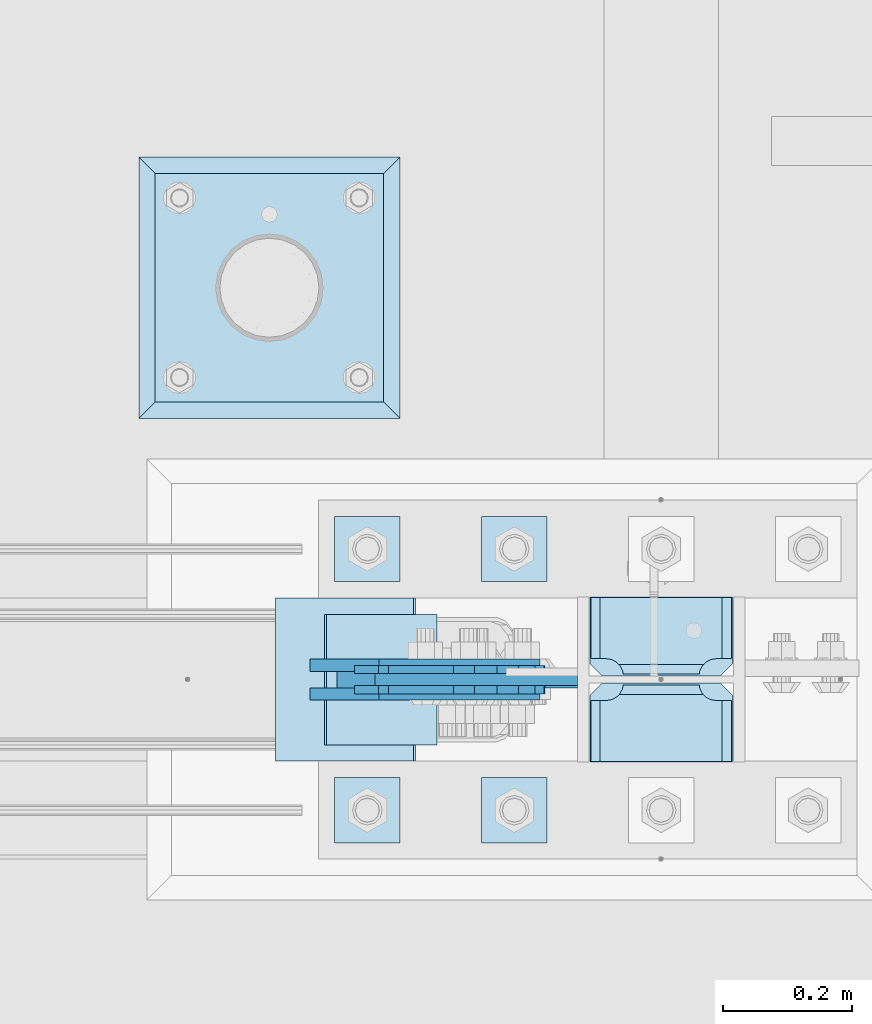
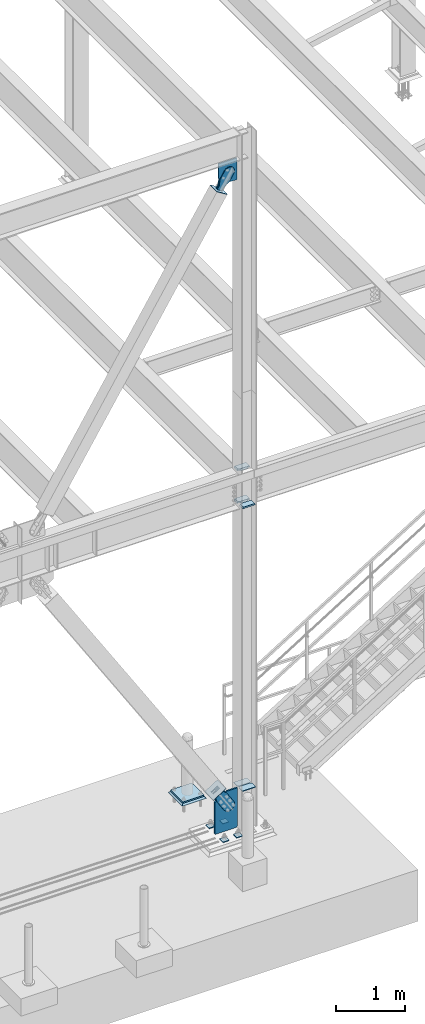
# One storey, part 3403 of 3843: 19 plates, 11 elements without a shape of their own.
"""IFC2X3 building model written with IfcOpenShell, lengths in millimetres."""

from ifc_helpers import new_model, si_unit, frame, origin_with_axes, place, context, subcontext, project, spatial, faceted_brep, material, type_object, element, aggregate, save


model = new_model("IFC2X3")

# Units and contexts
model_context = context("Model", 3, precision=1e-05, world=origin_with_axes())
body_context = subcontext(model_context, "Body", "Model", "MODEL_VIEW")
ifc_project = project(units=[si_unit("LENGTHUNIT", "METRE", prefix="MILLI"), si_unit("AREAUNIT", "SQUARE_METRE"), si_unit("VOLUMEUNIT", "CUBIC_METRE"), si_unit("MASSUNIT", "GRAM", prefix="KILO"), si_unit("TIMEUNIT", "SECOND"), si_unit("PLANEANGLEUNIT", "RADIAN"), si_unit("SOLIDANGLEUNIT", "STERADIAN"), si_unit("THERMODYNAMICTEMPERATUREUNIT", "DEGREE_CELSIUS"), si_unit("LUMINOUSINTENSITYUNIT", "LUMEN")], contexts=[model_context])

# Site, building, storey
site_placement = place(None, origin_with_axes())
site = spatial("IfcSite", under=ifc_project, at=site_placement, CompositionType="ELEMENT")
building_placement = place(site_placement, origin_with_axes())
building = spatial("IfcBuilding", under=site, at=building_placement, Name="Undefined", CompositionType="ELEMENT")
storey_placement = place(building_placement, origin_with_axes())
storey = spatial("IfcBuildingStorey", under=building, at=storey_placement, Name="Undefined", CompositionType="ELEMENT", Elevation=0.0)

# Assembly, plate
assembly_1_placement = place(storey_placement, origin_with_axes())
assembly_1 = element("IfcElementAssembly", 1, at=assembly_1_placement, inside=storey, Name="PIPE_BOLLARD", AssemblyPlace="NOTDEFINED", PredefinedType="RIGID_FRAME")
ifc_material_1 = material(Name="STEEL/A572-50")
plate_type_1 = type_object("IfcPlateType", PredefinedType="NOTDEFINED")
plate_1_placement = place(assembly_1_placement, frame((29692.6, 89547.7, 30518.1), z_axis=(0.0, 1.0, 0.0), x_axis=(1.0, 0.0, 0.0)))
plate_1 = element("IfcPlate", 2, at=plate_1_placement, type_object=plate_type_1, material=ifc_material_1, Name="PLATE", context=body_context, shape_type="Brep", body=[
    faceted_brep([(0.0, -12.6999999999971, 0.0), (0.0, -12.7000000000007, 355.600000000006), (0.0, 12.7000000000007, 355.600000000006), (0.0, 12.6999999999971, 0.0), (355.599999999999, -12.7000000000007, 355.600000000006), (355.599999999999, 12.7000000000007, 355.600000000006), (355.599999999999, -12.7000000000007, 0.0), (355.599999999999, 12.7000000000007, 0.0)], [[[0, 1, 2, 3]], [[1, 4, 5, 2]], [[4, 6, 7, 5]], [[6, 0, 3, 7]], [[5, 7, 3, 2]], [[6, 4, 1, 0]]]),
])
aggregate(assembly_1, [plate_1])

assembly_2_placement = place(storey_placement, origin_with_axes())
assembly_2 = element("IfcElementAssembly", 3, at=assembly_2_placement, inside=storey, Name="GROUT", AssemblyPlace="NOTDEFINED", PredefinedType="REINFORCEMENT_UNIT")
ifc_material_2 = material(Name="CONCRETE/Concrete_Undefined")
plate_type_2 = type_object("IfcPlateType", PredefinedType="NOTDEFINED")
plate_2_placement = place(assembly_2_placement, frame((29667.2, 89522.3, 30492.7), z_axis=(0.0, 1.0, 0.0), x_axis=(1.0, 0.0, 0.0)))
plate_2 = element("IfcPlate", 4, at=plate_2_placement, type_object=plate_type_2, material=ifc_material_2, Name="GROUT", context=body_context, shape_type="Brep", body=[
    faceted_brep([(25.4000000001906, -12.6999999998552, 380.999999999505), (0.0, 12.7000000000007, 406.399999999994), (0.0, 12.6999999999971, 0.0), (25.4000000001906, -12.6999999999898, 25.4000000004453), (380.999999999833, -12.6999999998588, 25.4000000004453), (406.400000000001, 12.7000000000007, 0.0), (406.400000000001, 12.7000000000007, 406.399999999994), (380.999999999833, -12.6999999999898, 380.999999999505)], [[[0, 1, 2, 3]], [[4, 5, 6, 7]], [[4, 7, 0, 3]], [[5, 4, 3, 2]], [[6, 5, 2, 1]], [[7, 6, 1, 0]]]),
])
aggregate(assembly_2, [plate_2])

# Assembly, plates
assembly_3_placement = place(storey_placement, origin_with_axes())
assembly_3 = element("IfcElementAssembly", 5, at=assembly_3_placement, inside=storey, Name="COLUMN", AssemblyPlace="NOTDEFINED", PredefinedType="RIGID_FRAME")
plate_type_3 = type_object("IfcPlateType", PredefinedType="NOTDEFINED")
plate_3_placement = place(assembly_3_placement, frame((30591.125, 88987.3125, 30822.7028906801), z_axis=(-1.0, 0.0, 0.0), x_axis=(0.0, 1.0, 0.0)))
plate_3 = element("IfcPlate", 6, at=plate_3_placement, type_object=plate_type_3, material=ifc_material_1, Name="STIFFENER", context=body_context, shape_type="Brep", body=[
    faceted_brep([(0.0, -6.3499999046162, 0.0), (0.0, -6.34999999999854, 222.25), (0.0, 6.34999999999854, 222.25), (7.27595761418343e-12, 6.3499999046162, 0.0), (103.981250762939, -6.34999999999854, 222.25), (103.981250762939, 6.34999999999854, 222.25), (123.03125, -6.34999999999854, 203.200000762939), (123.03125, 6.34999999999854, 203.200000762939), (123.03125, -6.34999999999854, 19.0499992370605), (123.03125, 6.34999999999854, 19.0499992370605), (103.981250762939, -6.34999999999854, 0.0), (103.981250762939, 6.34999999999854, 0.0)], [[[0, 1, 2, 3]], [[1, 4, 5, 2]], [[4, 6, 7, 5]], [[6, 8, 9, 7]], [[8, 10, 11, 9]], [[10, 0, 3, 11]], [[5, 7, 9, 11, 3, 2]], [[10, 8, 6, 4, 1, 0]]]),
])
plate_4_placement = place(assembly_3_placement, frame((30591.125, 89121.45625, 30822.7028906801), z_axis=(-1.0, 0.0, 0.0), x_axis=(0.0, 1.0, 0.0)))
plate_4 = element("IfcPlate", 7, at=plate_4_placement, type_object=plate_type_3, material=ifc_material_1, Name="STIFFENER", context=body_context, shape_type="Brep", body=[
    faceted_brep([(0.0, -6.34999999999854, 19.0499992370605), (0.0, -6.34999999999854, 203.200000762939), (0.0, 6.34999999999854, 203.200000762939), (0.0, 6.34999999999854, 19.0499992370605), (19.0499992370605, -6.34999999999854, 222.25), (19.0499992370605, 6.34999999999854, 222.25), (123.03125, -6.34999999999854, 222.25), (123.03125, 6.34999999999854, 222.25), (123.03125, -6.34999999999854, 0.0), (123.03125, 6.34999999999854, 0.0), (19.0499992370605, -6.34999999999854, 0.0), (19.0499992370605, 6.34999999999854, 0.0)], [[[0, 1, 2, 3]], [[1, 4, 5, 2]], [[4, 6, 7, 5]], [[6, 8, 9, 7]], [[8, 10, 11, 9]], [[10, 0, 3, 11]], [[5, 7, 9, 11, 3, 2]], [[10, 8, 6, 4, 1, 0]]]),
])
plate_type_4 = type_object("IfcPlateType", PredefinedType="NOTDEFINED")
plate_5_placement = place(assembly_3_placement, frame((30592.7125, 89110.34375, 35845.75), z_axis=(-1.0, 0.0, 0.0), x_axis=(0.0, -1.0, 0.0)))
plate_5 = element("IfcPlate", 8, at=plate_5_placement, type_object=plate_type_4, material=ifc_material_1, Name="PLATE", context=body_context, shape_type="Brep", body=[
    faceted_brep([(15.8628540477987, 9.2764413265686, 176.60415524448), (17.8394465694582, 12.6999999999971, 178.580747766144), (17.8394465694582, 12.6999999999971, 46.8442522338592), (15.8628540477985, 9.2764413265686, 48.8208447555226), (8.33959589993262, -3.75422402399272, 52.6541362449789), (3.17474995228986, -12.6999999999971, 53.4721674797547), (3.17474995228986, -12.6999999999971, 171.952832520248), (8.33959589993288, -3.75422402399272, 172.770863755024), (26.9874992430996, 12.6999999999971, 207.585803430506), (26.9874992435361, -12.6999999999971, 222.250500047681), (122.237500006479, -12.6999999999971, 222.250500047681), (122.237500006042, 12.6999999999971, 207.585803430506), (122.237500000527, 12.6999999999971, 17.8401965694902), (122.23750000009, -12.6999999999971, 3.17549995231457), (26.9874992371479, -12.6999999999971, 3.17549995231457), (26.9874992375844, 12.6999999999971, 17.8401965694902), (8.33959589993174, -12.6999999999971, 172.770863755024), (15.8628540477948, -12.6999999999971, 176.60415524448), (21.833345518462, -12.6999999999971, 182.574646715148), (21.833345518462, 12.6999999999971, 182.574646715148), (25.6666370079183, -12.6999999999971, 190.097904863011), (25.6666370079183, 12.6999999999971, 190.097904863011), (26.9874992370605, -12.6999999999971, 198.437500762942), (26.9874992370605, 12.6999999999971, 198.437500762942), (26.9874992370605, -12.6999999999971, 26.9874992370605), (26.9874992370605, 12.6999999999971, 26.9874992370605), (25.6666370079183, -12.6999999999971, 35.3270951369923), (25.6666370079183, 12.6999999999971, 35.3270951369923), (21.833345518462, -12.6999999999971, 42.8503532848626), (21.833345518462, 12.6999999999971, 42.8503532848626), (15.8628540477948, -12.6999999999971, 48.8208447555226), (8.33959589993174, -12.6999999999971, 52.6541362449789)], [[[0, 1, 2, 3, 4, 5, 6, 7]], [[8, 9, 10, 11]], [[12, 13, 14, 15]], [[16, 7, 6]], [[16, 17, 0, 7]], [[17, 18, 19, 1, 0]], [[18, 20, 21, 19]], [[20, 22, 23, 21]], [[23, 22, 9, 8]], [[13, 12, 11, 10]], [[24, 25, 15, 14]], [[24, 26, 27, 25]], [[26, 28, 29, 27]], [[29, 28, 30, 3, 2]], [[30, 31, 4, 3]], [[31, 5, 4]], [[19, 21, 23, 8, 11, 12, 15, 25, 27, 29, 2, 1]], [[31, 30, 28, 26, 24, 14, 13, 10, 9, 22, 20, 18, 17, 16, 6, 5]]]),
])
plate_6_placement = place(assembly_3_placement, frame((30592.7125, 89243.69375, 36423.6), z_axis=(-1.0, 0.0, 0.0), x_axis=(0.0, -1.0, 0.0)))
plate_6 = element("IfcPlate", 9, at=plate_6_placement, type_object=plate_type_4, material=ifc_material_1, Name="PLATE", context=body_context, shape_type="Brep", body=[
    faceted_brep([(106.374645952202, 9.2764413265686, 48.8208447555226), (104.398053430486, 12.6999999999971, 46.8442522338009), (104.398053430486, 12.6999999999971, 178.580747766202), (106.374645952201, 9.2764413265686, 176.60415524448), (113.897904100067, -3.75422402399272, 172.770863755024), (119.062750047655, -12.6999999999971, 171.952832520255), (119.062750047655, -12.6999999999971, 53.4721674797474), (113.897904100067, -3.75422402399272, 52.6541362449789), (95.2500007629424, 12.6999999999971, 17.8401965694866), (95.2500007629424, -12.6999999999971, 3.17549995231093), (0.0, -12.6999999999971, 3.17549995231093), (0.0, 12.6999999999971, 17.8401965694866), (0.0, 12.6999999999971, 207.585803430502), (0.0, -12.6999999999971, 222.250500047678), (95.2500007629424, -12.6999999999971, 222.250500047678), (95.2500007629424, 12.6999999999971, 207.585803430502), (95.2500007629424, -12.6999999999971, 198.437500762942), (95.2500007629424, 12.6999999999971, 198.437500762942), (96.5708629920846, -12.6999999999971, 190.097904863011), (96.5708629920846, 12.6999999999971, 190.097904863011), (100.404154481541, -12.6999999999971, 182.574646715148), (100.404154481541, 12.6999999999971, 182.574646715148), (106.374645952208, -12.6999999999971, 176.60415524448), (113.897904100071, -12.6999999999971, 172.770863755024), (113.897904100071, -12.6999999999971, 52.6541362449789), (106.374645952208, -12.6999999999971, 48.8208447555226), (100.404154481541, -12.6999999999971, 42.8503532848626), (100.404154481541, 12.6999999999971, 42.8503532848626), (96.5708629920846, -12.6999999999971, 35.3270951369923), (96.5708629920846, 12.6999999999971, 35.3270951369923), (95.2500007629424, -12.6999999999971, 26.9874992370605), (95.2500007629424, 12.6999999999971, 26.9874992370605)], [[[0, 1, 2, 3, 4, 5, 6, 7]], [[8, 9, 10, 11]], [[12, 13, 14, 15]], [[11, 10, 13, 12]], [[16, 17, 15, 14]], [[16, 18, 19, 17]], [[18, 20, 21, 19]], [[21, 20, 22, 3, 2]], [[22, 23, 4, 3]], [[23, 5, 4]], [[24, 7, 6]], [[24, 25, 0, 7]], [[25, 26, 27, 1, 0]], [[26, 28, 29, 27]], [[28, 30, 31, 29]], [[31, 30, 9, 8]], [[27, 29, 31, 8, 11, 12, 15, 17, 19, 21, 2, 1]], [[9, 30, 28, 26, 25, 24, 6, 5, 23, 22, 20, 18, 16, 14, 13, 10]]]),
])
plate_7_placement = place(assembly_3_placement, frame((30592.7125, 89243.69375, 35845.75), z_axis=(-1.0, 0.0, 0.0), x_axis=(0.0, -1.0, 0.0)))
plate_7 = element("IfcPlate", 10, at=plate_7_placement, type_object=plate_type_4, material=ifc_material_1, Name="PLATE", context=body_context, shape_type="Brep", body=[
    faceted_brep([(106.374645952202, 9.2764413265686, 48.8208447555226), (104.398053430486, 12.6999999999971, 46.8442522338009), (104.398053430486, 12.6999999999971, 178.580747766202), (106.374645952201, 9.2764413265686, 176.60415524448), (113.897904100067, -3.75422402399272, 172.770863755024), (119.062750047655, -12.6999999999971, 171.952832520255), (119.062750047655, -12.6999999999971, 53.4721674797474), (113.897904100067, -3.75422402399272, 52.6541362449789), (95.2500007629424, 12.6999999999971, 17.8401965694866), (95.2500007629424, -12.6999999999971, 3.17549995231093), (0.0, -12.6999999999971, 3.17549995231093), (0.0, 12.6999999999971, 17.8401965694866), (0.0, 12.6999999999971, 207.585803430502), (0.0, -12.6999999999971, 222.250500047678), (95.2500007629424, -12.6999999999971, 222.250500047678), (95.2500007629424, 12.6999999999971, 207.585803430502), (95.2500007629424, -12.6999999999971, 198.437500762942), (95.2500007629424, 12.6999999999971, 198.437500762942), (96.5708629920846, -12.6999999999971, 190.097904863011), (96.5708629920846, 12.6999999999971, 190.097904863011), (100.404154481541, -12.6999999999971, 182.574646715148), (100.404154481541, 12.6999999999971, 182.574646715148), (106.374645952208, -12.6999999999971, 176.60415524448), (113.897904100071, -12.6999999999971, 172.770863755024), (113.897904100071, -12.6999999999971, 52.6541362449789), (106.374645952208, -12.6999999999971, 48.8208447555226), (100.404154481541, -12.6999999999971, 42.8503532848626), (100.404154481541, 12.6999999999971, 42.8503532848626), (96.5708629920846, -12.6999999999971, 35.3270951369923), (96.5708629920846, 12.6999999999971, 35.3270951369923), (95.2500007629424, -12.6999999999971, 26.9874992370605), (95.2500007629424, 12.6999999999971, 26.9874992370605)], [[[0, 1, 2, 3, 4, 5, 6, 7]], [[8, 9, 10, 11]], [[12, 13, 14, 15]], [[11, 10, 13, 12]], [[16, 17, 15, 14]], [[16, 18, 19, 17]], [[18, 20, 21, 19]], [[21, 20, 22, 3, 2]], [[22, 23, 4, 3]], [[23, 5, 4]], [[24, 7, 6]], [[24, 25, 0, 7]], [[25, 26, 27, 1, 0]], [[26, 28, 29, 27]], [[28, 30, 31, 29]], [[31, 30, 9, 8]], [[27, 29, 31, 8, 11, 12, 15, 17, 19, 21, 2, 1]], [[9, 30, 28, 26, 25, 24, 6, 5, 23, 22, 20, 18, 16, 14, 13, 10]]]),
])

# Assembly, plate
assembly_4_placement = place(storey_placement, origin_with_axes())
assembly_4 = element("IfcElementAssembly", 11, at=assembly_4_placement, inside=storey, Name="CB", AssemblyPlace="NOTDEFINED", PredefinedType="RIGID_FRAME")
plate_type_5 = type_object("IfcPlateType", PredefinedType="NOTDEFINED")
plate_8_placement = place(assembly_4_placement, frame((30034.5357455699, 89115.9, 42002.075), z_axis=(0.0, 0.0, -1.0), x_axis=(1.0, 0.0, 0.0)))
plate_8 = element("IfcPlate", 12, at=plate_8_placement, type_object=plate_type_5, material=ifc_material_1, Name="CB", context=body_context, shape_type="Brep", body=[
    faceted_brep([(0.0, -9.52500000000146, 0.0), (0.0, -9.52500000174041, 261.15819008874), (0.0, 9.52499999824795, 261.15819008874), (0.0, 9.52500000000146, 0.0), (196.587902692983, -9.52500000254076, 383.929714229205), (196.587902692983, 9.52499999746215, 383.929714229205), (315.289254935127, -9.52500000254076, 383.929714229205), (315.289254935127, 9.52499999746215, 383.929714229205), (315.289254935127, -9.52500000002328, -7.27595761418343e-12), (315.289254935127, 9.52499999996508, -7.27595761418343e-12)], [[[0, 1, 2, 3]], [[1, 4, 5, 2]], [[4, 6, 7, 5]], [[6, 8, 9, 7]], [[8, 0, 3, 9]], [[5, 7, 9, 3, 2]], [[8, 6, 4, 1, 0]]]),
])
aggregate(assembly_4, [plate_8])

assembly_5_placement = place(storey_placement, origin_with_axes())
assembly_5 = element("IfcElementAssembly", 13, at=assembly_5_placement, inside=storey, AssemblyPlace="NOTDEFINED", PredefinedType="RIGID_FRAME")
ifc_material_3 = material(Name="STEEL/A36")
plate_type_6 = type_object("IfcPlateType", PredefinedType="NOTDEFINED")
plate_9_placement = place(assembly_5_placement, frame((30080.8586551978, 89131.7750061035, 41509.8499132243), z_axis=(-0.848184242744672, 0.0, 0.52970132184057), x_axis=(0.529701321840548, 0.0, 0.848184242744686)))
plate_9 = element("IfcPlate", 14, at=plate_9_placement, type_object=plate_type_6, material=ifc_material_3, context=body_context, shape_type="Brep", body=[
    faceted_brep([(0.0, -6.3499999046162, 0.0), (2.18278728425503e-10, -6.35000000000582, 91.5986124321353), (2.18278728425503e-10, 6.35000000000582, 91.5986124321353), (7.27595761418343e-12, 6.3499999046162, 0.0), (69.8499999987471, -6.35000000000582, 91.598612432037), (69.8499999987471, 6.35000000000582, 91.598612432037), (171.44999999673, -6.35000000000582, 136.286806214401), (171.44999999673, 6.35000000000582, 136.286806214401), (316.534985839971, -6.35000000000582, 136.286806214212), (316.534985839971, 6.35000000000582, 136.286806214212), (351.163054093879, -6.35000000000582, 129.398855179952), (351.163054093879, 6.35000000000582, 129.398855179952), (380.51931286032, -6.35000000000582, 109.783630182814), (380.51931286032, 6.35000000000582, 109.783630182814), (400.134537857251, -6.35000000000582, 80.42737141615), (400.134537857251, 6.35000000000582, 80.42737141615), (407.022488891344, -6.35000000000582, 45.7993092690485), (407.022488891344, 6.35000000000582, 45.7993092690485), (400.134537857084, -6.35000000000582, 11.1712410149557), (400.134537857084, 6.35000000000582, 11.1712410149557), (380.519312860015, -6.35000000000582, -18.1850177516608), (380.519312860015, 6.35000000000582, -18.1850177516608), (351.163054093486, -6.35000000000582, -37.8002427487263), (351.163054093486, 6.35000000000582, -37.8002427487263), (316.534988893036, -6.35000000000582, -44.6881937828948), (316.534988893036, 6.35000000000582, -44.6881937828948), (171.449999996279, -6.35000000000582, -44.6881937827056), (171.449999996279, 6.35000000000582, -44.6881937827056), (69.8499999985434, -6.35000000000582, -8.73114913702011e-11), (69.8499999985434, 6.35000000000582, -8.73114913702011e-11)], [[[0, 1, 2, 3]], [[1, 4, 5, 2]], [[4, 6, 7, 5]], [[6, 8, 9, 7]], [[8, 10, 11, 9]], [[10, 12, 13, 11]], [[12, 14, 15, 13]], [[14, 16, 17, 15]], [[16, 18, 19, 17]], [[18, 20, 21, 19]], [[20, 22, 23, 21]], [[22, 24, 25, 23]], [[24, 26, 27, 25]], [[26, 28, 29, 27]], [[28, 0, 3, 29]], [[5, 7, 9, 11, 13, 15, 17, 19, 21, 23, 25, 27, 29, 3, 2]], [[28, 26, 24, 22, 20, 18, 16, 14, 12, 10, 8, 6, 4, 1, 0]]]),
])
aggregate(assembly_5, [plate_9])

assembly_6_placement = place(storey_placement, origin_with_axes())
assembly_6 = element("IfcElementAssembly", 15, at=assembly_6_placement, inside=storey, AssemblyPlace="NOTDEFINED", PredefinedType="RIGID_FRAME")
plate_10_placement = place(assembly_6_placement, frame((30080.8586551978, 89100.0250061035, 41509.8499132243), z_axis=(-0.848184242744672, 0.0, 0.52970132184057), x_axis=(0.529701321840548, 0.0, 0.848184242744686)))
plate_10 = element("IfcPlate", 16, at=plate_10_placement, type_object=plate_type_6, material=ifc_material_3, context=body_context, shape_type="Brep", body=[
    faceted_brep([(0.0, -6.3499999046162, 0.0), (2.18278728425503e-10, -6.35000000000582, 91.5986124321353), (2.18278728425503e-10, 6.35000000000582, 91.5986124321353), (7.27595761418343e-12, 6.3499999046162, 0.0), (69.8499999987471, -6.35000000000582, 91.598612432037), (69.8499999987471, 6.35000000000582, 91.598612432037), (171.44999999673, -6.35000000000582, 136.286806214401), (171.44999999673, 6.35000000000582, 136.286806214401), (316.534985839971, -6.35000000000582, 136.286806214212), (316.534985839971, 6.35000000000582, 136.286806214212), (351.163054093879, -6.35000000000582, 129.398855179952), (351.163054093879, 6.35000000000582, 129.398855179952), (380.51931286032, -6.35000000000582, 109.783630182814), (380.51931286032, 6.35000000000582, 109.783630182814), (400.134537857251, -6.35000000000582, 80.42737141615), (400.134537857251, 6.35000000000582, 80.42737141615), (407.022488891344, -6.35000000000582, 45.7993092690485), (407.022488891344, 6.35000000000582, 45.7993092690485), (400.134537857084, -6.35000000000582, 11.1712410149557), (400.134537857084, 6.35000000000582, 11.1712410149557), (380.519312860015, -6.35000000000582, -18.1850177516608), (380.519312860015, 6.35000000000582, -18.1850177516608), (351.163054093486, -6.35000000000582, -37.8002427487263), (351.163054093486, 6.35000000000582, -37.8002427487263), (316.534988893036, -6.35000000000582, -44.6881937828948), (316.534988893036, 6.35000000000582, -44.6881937828948), (171.449999996279, -6.35000000000582, -44.6881937827056), (171.449999996279, 6.35000000000582, -44.6881937827056), (69.8499999985434, -6.35000000000582, -8.73114913702011e-11), (69.8499999985434, 6.35000000000582, -8.73114913702011e-11)], [[[0, 1, 2, 3]], [[1, 4, 5, 2]], [[4, 6, 7, 5]], [[6, 8, 9, 7]], [[8, 10, 11, 9]], [[10, 12, 13, 11]], [[12, 14, 15, 13]], [[14, 16, 17, 15]], [[16, 18, 19, 17]], [[18, 20, 21, 19]], [[20, 22, 23, 21]], [[22, 24, 25, 23]], [[24, 26, 27, 25]], [[26, 28, 29, 27]], [[28, 0, 3, 29]], [[5, 7, 9, 11, 13, 15, 17, 19, 21, 23, 25, 27, 29, 3, 2]], [[28, 26, 24, 22, 20, 18, 16, 14, 12, 10, 8, 6, 4, 1, 0]]]),
])
aggregate(assembly_6, [plate_10])

assembly_7_placement = place(storey_placement, origin_with_axes())
assembly_7 = element("IfcElementAssembly", 17, at=assembly_7_placement, inside=storey, Name="Plate", AssemblyPlace="NOTDEFINED", PredefinedType="RIGID_FRAME")
plate_type_7 = type_object("IfcPlateType", PredefinedType="NOTDEFINED")
plate_11_placement = place(assembly_7_placement, frame((30129.8697261076, 89014.3000061035, 41482.9851969502), z_axis=(-0.848184242744672, 0.0, 0.52970132184057), x_axis=(0.0, 1.0, 0.0)))
plate_11 = element("IfcPlate", 18, at=plate_11_placement, type_object=plate_type_7, material=ifc_material_3, Name="Plate", context=body_context, shape_type="Brep", body=[
    faceted_brep([(0.0, -3.17499999999927, 0.0), (0.0, -3.17500000043947, 203.200000001736), (0.0, 3.1749999995518, 203.200000001743), (0.0, 3.17499999999927, 0.0), (203.200000000012, -3.17500000043947, 203.200000001736), (203.200000000012, 3.1749999995518, 203.200000001743), (203.199996948242, -3.17499999999927, 0.0), (203.199996948242, 3.17499999999927, 0.0)], [[[0, 1, 2, 3]], [[1, 4, 5, 2]], [[4, 6, 7, 5]], [[6, 0, 3, 7]], [[5, 7, 3, 2]], [[6, 4, 1, 0]]]),
])
aggregate(assembly_7, [plate_11])

# Assembly, plates
assembly_8_placement = place(storey_placement, origin_with_axes())
assembly_8 = element("IfcElementAssembly", 19, at=assembly_8_placement, inside=storey, Name="TEMPLATE", AssemblyPlace="NOTDEFINED", PredefinedType="RIGID_FRAME")
plate_type_8 = type_object("IfcPlateType", PredefinedType="NOTDEFINED")
plate_12_placement = place(assembly_8_placement, frame((30200.6, 88963.5, 30130.75), z_axis=(0.0, -1.0, 0.0), x_axis=(1.0, 0.0, 0.0)))
plate_12 = element("IfcPlate", 20, at=plate_12_placement, type_object=plate_type_8, material=ifc_material_1, Name="Washer Plate", context=body_context, shape_type="Brep", body=[
    faceted_brep([(0.0, -6.3499999046162, 0.0), (-1.67347025126219e-10, -6.35000000000582, 101.600000000151), (-1.67347025126219e-10, 6.35000000000582, 101.600000000151), (7.27595761418343e-12, 6.3499999046162, 0.0), (101.599998474121, -6.34999999999854, 101.599998474121), (101.599998474121, 6.34999999999854, 101.599998474121), (101.6, -6.34999999999854, 0.0), (101.6, 6.34999999999854, 0.0)], [[[0, 1, 2, 3]], [[1, 4, 5, 2]], [[4, 6, 7, 5]], [[6, 0, 3, 7]], [[5, 7, 3, 2]], [[6, 4, 1, 0]]]),
])
plate_13_placement = place(assembly_8_placement, frame((30200.6, 89369.9, 30130.75), z_axis=(0.0, -1.0, 0.0), x_axis=(1.0, 0.0, 0.0)))
plate_13 = element("IfcPlate", 21, at=plate_13_placement, type_object=plate_type_8, material=ifc_material_1, Name="Washer Plate", context=body_context, shape_type="Brep", body=[
    faceted_brep([(0.0, -6.3499999046162, 0.0), (-1.67347025126219e-10, -6.35000000000582, 101.600000000151), (-1.67347025126219e-10, 6.35000000000582, 101.600000000151), (7.27595761418343e-12, 6.3499999046162, 0.0), (101.599998474121, -6.34999999999854, 101.599998474121), (101.599998474121, 6.34999999999854, 101.599998474121), (101.6, -6.34999999999854, 0.0), (101.6, 6.34999999999854, 0.0)], [[[0, 1, 2, 3]], [[1, 4, 5, 2]], [[4, 6, 7, 5]], [[6, 0, 3, 7]], [[5, 7, 3, 2]], [[6, 4, 1, 0]]]),
])
plate_14_placement = place(assembly_8_placement, frame((29972.0, 88963.5, 30130.75), z_axis=(0.0, -1.0, 0.0), x_axis=(1.0, 0.0, 0.0)))
plate_14 = element("IfcPlate", 22, at=plate_14_placement, type_object=plate_type_8, material=ifc_material_1, Name="Washer Plate", context=body_context, shape_type="Brep", body=[
    faceted_brep([(0.0, -6.3499999046162, 0.0), (-1.67347025126219e-10, -6.35000000000582, 101.600000000151), (-1.67347025126219e-10, 6.35000000000582, 101.600000000151), (7.27595761418343e-12, 6.3499999046162, 0.0), (101.599998474121, -6.34999999999854, 101.599998474121), (101.599998474121, 6.34999999999854, 101.599998474121), (101.6, -6.34999999999854, 0.0), (101.6, 6.34999999999854, 0.0)], [[[0, 1, 2, 3]], [[1, 4, 5, 2]], [[4, 6, 7, 5]], [[6, 0, 3, 7]], [[5, 7, 3, 2]], [[6, 4, 1, 0]]]),
])
plate_15_placement = place(assembly_8_placement, frame((29972.0, 89369.9, 30130.75), z_axis=(0.0, -1.0, 0.0), x_axis=(1.0, 0.0, 0.0)))
plate_15 = element("IfcPlate", 23, at=plate_15_placement, type_object=plate_type_8, material=ifc_material_1, Name="Washer Plate", context=body_context, shape_type="Brep", body=[
    faceted_brep([(0.0, -6.3499999046162, 0.0), (-1.67347025126219e-10, -6.35000000000582, 101.600000000151), (-1.67347025126219e-10, 6.35000000000582, 101.600000000151), (7.27595761418343e-12, 6.3499999046162, 0.0), (101.599998474121, -6.34999999999854, 101.599998474121), (101.599998474121, 6.34999999999854, 101.599998474121), (101.6, -6.34999999999854, 0.0), (101.6, 6.34999999999854, 0.0)], [[[0, 1, 2, 3]], [[1, 4, 5, 2]], [[4, 6, 7, 5]], [[6, 0, 3, 7]], [[5, 7, 3, 2]], [[6, 4, 1, 0]]]),
])
aggregate(assembly_8, [plate_12, plate_13, plate_14, plate_15])

# Plate
plate_type_9 = type_object("IfcPlateType", PredefinedType="NOTDEFINED")
plate_16_placement = place(assembly_3_placement, frame((30349.825, 89115.9, 30124.4), z_axis=(0.0, 0.0, 1.0), x_axis=(-1.0, 0.0, 0.0)))
plate_16 = element("IfcPlate", 24, at=plate_16_placement, type_object=plate_type_9, material=ifc_material_1, Name="CB", context=body_context, shape_type="Brep", body=[
    faceted_brep([(0.0, -12.6999999999971, 19.0499992370605), (0.0, -12.6999999999971, 698.302890680108), (0.0, 12.6999999999971, 698.302890680108), (0.0, 12.6999999999971, 19.0499992370605), (167.760511938497, -12.6999999999971, 698.302890680108), (167.760511938497, 12.6999999999971, 698.302890680108), (374.243401923715, -12.6999999999971, 567.410408969536), (374.243401923715, 12.6999999999971, 567.410408969536), (374.243401923715, -12.6999999999971, 0.0), (374.243401923715, 12.6999999999971, 0.0), (19.0500015258731, -12.6999999999971, -6.33008312433958e-10), (19.0500015258731, 12.6999999999971, 0.0)], [[[0, 1, 2, 3]], [[1, 4, 5, 2]], [[4, 6, 7, 5]], [[6, 8, 9, 7]], [[8, 10, 11, 9]], [[10, 0, 3, 11]], [[5, 7, 9, 11, 3, 2]], [[10, 8, 6, 4, 1, 0]]]),
])

aggregate(assembly_3, [plate_3, plate_4, plate_16, plate_5, plate_6, plate_7])

# Assembly, plate
assembly_9_placement = place(storey_placement, origin_with_axes())
assembly_9 = element("IfcElementAssembly", 25, at=assembly_9_placement, inside=storey, AssemblyPlace="NOTDEFINED", PredefinedType="RIGID_FRAME")
plate_type_10 = type_object("IfcPlateType", PredefinedType="NOTDEFINED")
plate_17_placement = place(assembly_9_placement, frame((30040.6714072623, 89138.1250061035, 30936.0679617987), z_axis=(-0.844597157113068, 0.0, -0.535402318071675), x_axis=(0.535402318071675, 0.0, -0.844597157113068)))
plate_17 = element("IfcPlate", 26, at=plate_17_placement, type_object=plate_type_10, material=ifc_material_3, context=body_context, shape_type="Brep", body=[
    faceted_brep([(0.0, -9.52500000000146, 0.0), (-1.04046193882823e-09, -9.52499999999418, 127.02645557576), (-1.04046193882823e-09, 9.52499999999418, 127.02645557576), (0.0, 9.52500000000146, 0.0), (69.8499999968899, -9.52499999999418, 127.026455575353), (69.8499999968899, 9.52499999999418, 127.026455575353), (171.449999994144, -9.52499999999418, 160.350727789177), (171.449999994144, 9.52499999999418, 160.350727789177), (390.129297651329, -9.52499999999418, 160.350727787925), (390.129297651329, 9.52499999999418, 160.350727787925), (427.187405116643, -9.52499999999418, 152.979411901222), (427.187405116643, 9.52499999999418, 152.979411901222), (458.603751652932, -9.52499999999418, 131.987680264123), (458.603751652932, 9.52499999999418, 131.987680264123), (479.595483290015, -9.52499999999418, 100.571333727821), (479.595483290015, 9.52499999999418, 100.571333727821), (486.966799176706, -9.52499999999418, 63.5132293100978), (486.966799176706, 9.52499999999418, 63.5132293100978), (479.595483290208, -9.52499999999418, 26.4551218441993), (479.595483290208, 9.52499999999418, 26.4551218441993), (458.603751652907, -9.52499999999418, -4.96122469259717), (458.603751652907, 9.52499999999418, -4.96122469259717), (427.187405116098, -9.52499999999418, -25.9529563298856), (427.187405116098, 9.52499999999418, -25.9529563298856), (390.129299180044, -9.52499999999418, -33.3242722163704), (390.129299180044, 9.52499999999418, -33.3242722163704), (171.449999995208, -9.52499999999418, -33.3242722151044), (171.449999995208, 9.52499999999418, -33.3242722151044), (69.8499999979995, -9.52499999999418, -4.00177668780088e-10), (69.8499999979995, 9.52499999999418, -4.00177668780088e-10)], [[[0, 1, 2, 3]], [[1, 4, 5, 2]], [[4, 6, 7, 5]], [[6, 8, 9, 7]], [[8, 10, 11, 9]], [[10, 12, 13, 11]], [[12, 14, 15, 13]], [[14, 16, 17, 15]], [[16, 18, 19, 17]], [[18, 20, 21, 19]], [[20, 22, 23, 21]], [[22, 24, 25, 23]], [[24, 26, 27, 25]], [[26, 28, 29, 27]], [[28, 0, 3, 29]], [[5, 7, 9, 11, 13, 15, 17, 19, 21, 23, 25, 27, 29, 3, 2]], [[28, 26, 24, 22, 20, 18, 16, 14, 12, 10, 8, 6, 4, 1, 0]]]),
])
aggregate(assembly_9, [plate_17])

assembly_10_placement = place(storey_placement, origin_with_axes())
assembly_10 = element("IfcElementAssembly", 27, at=assembly_10_placement, inside=storey, AssemblyPlace="NOTDEFINED", PredefinedType="RIGID_FRAME")
plate_18_placement = place(assembly_10_placement, frame((30040.6714072623, 89093.6750061035, 30936.0679617987), z_axis=(-0.844597157113068, 0.0, -0.535402318071675), x_axis=(0.535402318071675, 0.0, -0.844597157113068)))
plate_18 = element("IfcPlate", 28, at=plate_18_placement, type_object=plate_type_10, material=ifc_material_3, context=body_context, shape_type="Brep", body=[
    faceted_brep([(0.0, -9.52500000000146, 0.0), (-1.04046193882823e-09, -9.52499999999418, 127.02645557576), (-1.04046193882823e-09, 9.52499999999418, 127.02645557576), (0.0, 9.52500000000146, 0.0), (69.8499999968899, -9.52499999999418, 127.026455575353), (69.8499999968899, 9.52499999999418, 127.026455575353), (171.449999994144, -9.52499999999418, 160.350727789177), (171.449999994144, 9.52499999999418, 160.350727789177), (390.129297651329, -9.52499999999418, 160.350727787925), (390.129297651329, 9.52499999999418, 160.350727787925), (427.187405116643, -9.52499999999418, 152.979411901222), (427.187405116643, 9.52499999999418, 152.979411901222), (458.603751652932, -9.52499999999418, 131.987680264123), (458.603751652932, 9.52499999999418, 131.987680264123), (479.595483290015, -9.52499999999418, 100.571333727821), (479.595483290015, 9.52499999999418, 100.571333727821), (486.966799176706, -9.52499999999418, 63.5132293100978), (486.966799176706, 9.52499999999418, 63.5132293100978), (479.595483290208, -9.52499999999418, 26.4551218441993), (479.595483290208, 9.52499999999418, 26.4551218441993), (458.603751652907, -9.52499999999418, -4.96122469259717), (458.603751652907, 9.52499999999418, -4.96122469259717), (427.187405116098, -9.52499999999418, -25.9529563298856), (427.187405116098, 9.52499999999418, -25.9529563298856), (390.129299180044, -9.52499999999418, -33.3242722163704), (390.129299180044, 9.52499999999418, -33.3242722163704), (171.449999995208, -9.52499999999418, -33.3242722151044), (171.449999995208, 9.52499999999418, -33.3242722151044), (69.8499999979995, -9.52499999999418, -4.00177668780088e-10), (69.8499999979995, 9.52499999999418, -4.00177668780088e-10)], [[[0, 1, 2, 3]], [[1, 4, 5, 2]], [[4, 6, 7, 5]], [[6, 8, 9, 7]], [[8, 10, 11, 9]], [[10, 12, 13, 11]], [[12, 14, 15, 13]], [[14, 16, 17, 15]], [[16, 18, 19, 17]], [[18, 20, 21, 19]], [[20, 22, 23, 21]], [[22, 24, 25, 23]], [[24, 26, 27, 25]], [[26, 28, 29, 27]], [[28, 0, 3, 29]], [[5, 7, 9, 11, 13, 15, 17, 19, 21, 23, 25, 27, 29, 3, 2]], [[28, 26, 24, 22, 20, 18, 16, 14, 12, 10, 8, 6, 4, 1, 0]]]),
])
aggregate(assembly_10, [plate_18])

assembly_11_placement = place(storey_placement, origin_with_axes())
assembly_11 = element("IfcElementAssembly", 29, at=assembly_11_placement, inside=storey, Name="Plate", AssemblyPlace="NOTDEFINED", PredefinedType="RIGID_FRAME")
plate_type_11 = type_object("IfcPlateType", PredefinedType="NOTDEFINED")
plate_19_placement = place(assembly_11_placement, frame((29881.4643790402, 89242.9000061035, 30831.3851420452), z_axis=(0.844597157113068, 0.0, 0.535402318071675), x_axis=(0.0, -1.0, 0.0)))
plate_19 = element("IfcPlate", 30, at=plate_19_placement, type_object=plate_type_11, material=ifc_material_3, Name="Plate", context=body_context, shape_type="Brep", body=[
    faceted_brep([(0.0, -3.17499999999927, 0.0), (0.0, -3.17499999965185, 254.000000005151), (0.0, 3.17500000035216, 254.000000005166), (0.0, 3.17499999999927, 0.0), (254.0, -3.17499999965185, 254.000000005151), (254.0, 3.17500000035216, 254.000000005166), (254.0, -3.17500000000291, 0.0), (254.0, 3.17499999999927, 1.45519152283669e-11)], [[[0, 1, 2, 3]], [[1, 4, 5, 2]], [[4, 6, 7, 5]], [[6, 0, 3, 7]], [[5, 7, 3, 2]], [[6, 4, 1, 0]]]),
])
aggregate(assembly_11, [plate_19])

save(model, "model.ifc")
